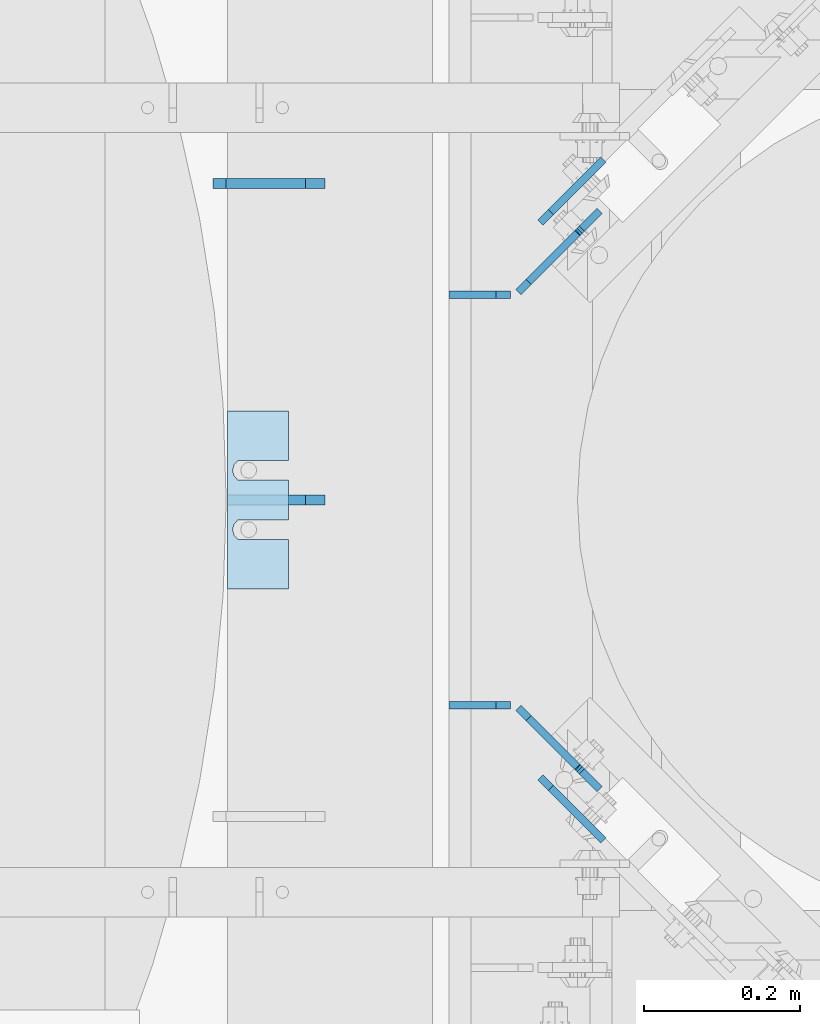
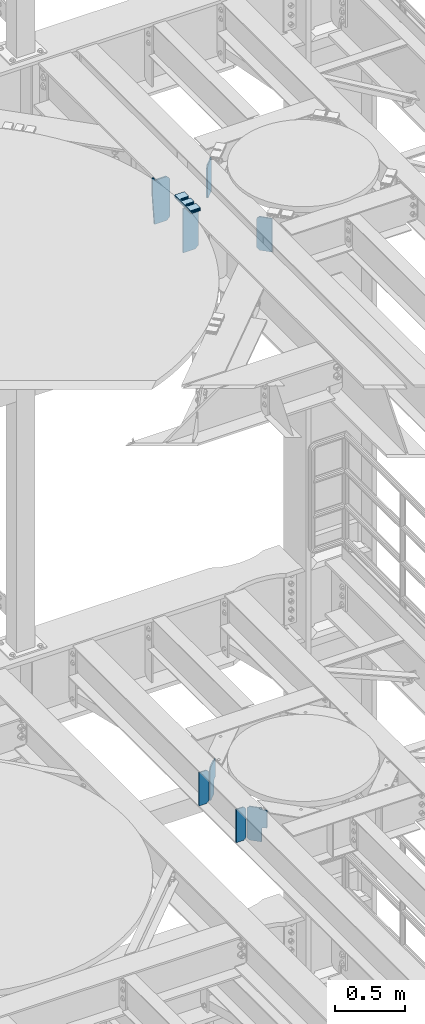
# One storey, part 1789 of 1876: 14 plates, 9 elements without a shape of their own.
"""IFC2X3 building model written with IfcOpenShell, lengths in millimetres."""

from ifc_helpers import new_model, si_unit, frame, origin_with_axes, place, context, subcontext, project, spatial, faceted_brep, material, type_object, element, aggregate, save


model = new_model("IFC2X3")

# Units and contexts
model_context = context("Model", 3, precision=1e-05, world=origin_with_axes())
body_context = subcontext(model_context, "Body", "Model", "MODEL_VIEW")
ifc_project = project(units=[si_unit("LENGTHUNIT", "METRE", prefix="MILLI"), si_unit("AREAUNIT", "SQUARE_METRE"), si_unit("VOLUMEUNIT", "CUBIC_METRE"), si_unit("MASSUNIT", "GRAM", prefix="KILO"), si_unit("TIMEUNIT", "SECOND"), si_unit("PLANEANGLEUNIT", "RADIAN"), si_unit("SOLIDANGLEUNIT", "STERADIAN"), si_unit("THERMODYNAMICTEMPERATUREUNIT", "DEGREE_CELSIUS"), si_unit("LUMINOUSINTENSITYUNIT", "LUMEN")], contexts=[model_context])

# Site, building, storey
site_placement = place(None, origin_with_axes())
site = spatial("IfcSite", under=ifc_project, at=site_placement, CompositionType="ELEMENT")
building_placement = place(site_placement, origin_with_axes())
building = spatial("IfcBuilding", under=site, at=building_placement, Name="Undefined", CompositionType="ELEMENT")
storey_placement = place(building_placement, origin_with_axes())
storey = spatial("IfcBuildingStorey", under=building, at=storey_placement, Name="Undefined", CompositionType="ELEMENT", Elevation=0.0)

# Assembly, plates
assembly_1_placement = place(storey_placement, origin_with_axes())
assembly_1 = element("IfcElementAssembly", 1, at=assembly_1_placement, inside=storey, Name="BEAM", AssemblyPlace="NOTDEFINED", PredefinedType="RIGID_FRAME")
ifc_material = material(Name="STEEL/A36")
plate_type_1 = type_object("IfcPlateType", PredefinedType="NOTDEFINED")
plate_1_placement = place(assembly_1_placement, frame((5483.225, 11217.5243572982, 7851.775), z_axis=(0.0, 0.0, 1.0), x_axis=(-1.0, 0.0, 0.0)))
plate_1 = element("IfcPlate", 2, at=plate_1_placement, type_object=plate_type_1, material=ifc_material, Name="PLATE", context=body_context, shape_type="Brep", body=[
    faceted_brep([(0.0, -4.76249999999982, 19.0499992370605), (0.0, -4.76250000000073, 269.874988555908), (0.0, 4.76250000000073, 269.874988555908), (0.0, 4.76249999999982, 19.0499992370605), (19.0499992370605, -4.76250000000073, 288.924987792969), (19.0499992370605, 4.76250000000073, 288.924987792969), (79.375, -4.76250000000073, 288.924987792969), (79.375, 4.76250000000073, 288.924987792969), (79.375, -4.76250000000073, 0.0), (79.375, 4.76250000000073, 0.0), (19.0499992370605, -4.76249999999982, 0.0), (19.0499992370605, 4.76249999999982, 0.0)], [[[0, 1, 2, 3]], [[1, 4, 5, 2]], [[4, 6, 7, 5]], [[6, 8, 9, 7]], [[8, 10, 11, 9]], [[10, 0, 3, 11]], [[5, 7, 9, 11, 3, 2]], [[10, 8, 6, 4, 1, 0]]]),
])
plate_2_placement = place(assembly_1_placement, frame((5483.225, 11744.0756426965, 7851.775), z_axis=(0.0, 0.0, 1.0), x_axis=(-1.0, 0.0, 0.0)))
plate_2 = element("IfcPlate", 3, at=plate_2_placement, type_object=plate_type_1, material=ifc_material, Name="PLATE", context=body_context, shape_type="Brep", body=[
    faceted_brep([(0.0, -4.76249999999982, 19.0499992370605), (0.0, -4.76250000000073, 269.874988555908), (0.0, 4.76250000000073, 269.874988555908), (0.0, 4.76249999999982, 19.0499992370605), (19.0499992370605, -4.76250000000073, 288.924987792969), (19.0499992370605, 4.76250000000073, 288.924987792969), (79.375, -4.76250000000073, 288.924987792969), (79.375, 4.76250000000073, 288.924987792969), (79.375, -4.76250000000073, 0.0), (79.375, 4.76250000000073, 0.0), (19.0499992370605, -4.76249999999982, 0.0), (19.0499992370605, 4.76249999999982, 0.0)], [[[0, 1, 2, 3]], [[1, 4, 5, 2]], [[4, 6, 7, 5]], [[6, 8, 9, 7]], [[8, 10, 11, 9]], [[10, 0, 3, 11]], [[5, 7, 9, 11, 3, 2]], [[10, 8, 6, 4, 1, 0]]]),
])
plate_type_2 = type_object("IfcPlateType", PredefinedType="NOTDEFINED")
plate_3_placement = place(assembly_1_placement, frame((5492.9414299445, 11214.1593446803, 7869.2375), z_axis=(0.500120633849916, -0.499879336849988, 0.707106781319465), x_axis=(0.500120634037912, -0.499879337037939, -0.707106781053631)))
plate_3 = element("IfcPlate", 4, at=plate_3_placement, type_object=plate_type_2, material=ifc_material, Name="PLATE", context=body_context, shape_type="Brep", body=[
    faceted_brep([(0.0, -4.76249999999982, 0.0), (-179.605117797772, -4.76249999999527, 179.605117797992), (-179.605117797772, 4.76250000000437, 179.605117797993), (0.0, 4.76249999999982, 0.0), (-179.605117797761, -4.76249999999891, 206.545883178862), (-179.605117797761, 4.76250000000255, 206.545883178861), (-117.085624694717, -4.76250000001346, 269.065399170066), (-117.085624694717, 4.76249999998618, 269.065399170067), (-115.963089848394, -4.76250000001346, 267.942865171457), (-115.963089848394, 4.76249999998618, 267.942865171458), (-111.842913448323, -4.76250000001346, 265.189853285486), (-111.842913448321, 4.76249999998618, 265.189853285486), (-106.982834855353, -4.76250000001528, 264.223124739228), (-106.982834855355, 4.76249999998618, 264.223124739228), (-102.122756627408, -4.7625000000171, 265.189855120591), (-102.122756627408, 4.76249999998436, 265.189855120592), (-98.0025812668409, -4.7625000000171, 267.942868562291), (-98.0025812668409, 4.76249999998436, 267.942868562292), (-78.5502777098482, -4.76250000002074, 287.395172119276), (-78.55027770985, 4.76249999997708, 287.395172119276), (29.2127933502834, -4.76250000002437, 179.632080078175), (29.2127933502834, 4.76249999997526, 179.632080078175), (13.1280894640131, -4.76250000002074, 163.547375922156), (13.1280894640131, 4.7624999999789, 163.547375922156), (9.34269542473339, -4.76250000002074, 157.882133286667), (9.34269542473339, 4.76249999998072, 157.882133286666), (8.01344184574918, -4.76250000001892, 151.199523985329), (8.01344184574918, 4.76249999998072, 151.199523985328), (9.34269553466402, -4.76250000001892, 144.516914705855), (9.34269553466402, 4.76249999998254, 144.516914705854), (13.1280896671378, -4.76250000001892, 138.851672132636), (13.1280896671378, 4.76249999998072, 138.851672132635), (89.4602661132976, -4.76250000002256, 62.5194969177073), (89.4602661132976, 4.7624999999789, 62.5194969177082), (26.9407691955548, -4.76250000000618, -2.22826201934367e-11), (26.9407691955548, 4.76249999999345, -2.22826201934367e-11)], [[[0, 1, 2, 3]], [[1, 4, 5, 2]], [[4, 6, 7, 5]], [[6, 8, 9, 7]], [[8, 10, 11, 9]], [[10, 12, 13, 11]], [[12, 14, 15, 13]], [[14, 16, 17, 15]], [[16, 18, 19, 17]], [[18, 20, 21, 19]], [[20, 22, 23, 21]], [[22, 24, 25, 23]], [[24, 26, 27, 25]], [[26, 28, 29, 27]], [[28, 30, 31, 29]], [[30, 32, 33, 31]], [[32, 34, 35, 33]], [[34, 0, 3, 35]], [[5, 7, 9, 11, 13, 15, 17, 19, 21, 23, 25, 27, 29, 31, 33, 35, 3, 2]], [[34, 32, 30, 28, 26, 24, 22, 20, 18, 16, 14, 12, 10, 8, 6, 4, 1, 0]]]),
])
plate_4_placement = place(assembly_1_placement, frame((5492.94142994366, 11747.4406553139, 7869.2375), z_axis=(0.500120633849922, 0.499879336849994, 0.707106781319457), x_axis=(0.500120634037941, 0.499879337037901, -0.707106781053638)))
plate_4 = element("IfcPlate", 5, at=plate_4_placement, type_object=plate_type_2, material=ifc_material, Name="PLATE", context=body_context, shape_type="Brep", body=[
    faceted_brep([(0.0, -4.76249999999982, 0.0), (-179.605117797772, -4.76249999999527, 179.605117797992), (-179.605117797772, 4.76250000000437, 179.605117797993), (0.0, 4.76249999999982, 0.0), (-179.605117797761, -4.76249999999891, 206.545883178862), (-179.605117797761, 4.76250000000255, 206.545883178861), (-117.085624694717, -4.76250000001346, 269.065399170066), (-117.085624694717, 4.76249999998618, 269.065399170067), (-115.963089848394, -4.76250000001346, 267.942865171457), (-115.963089848394, 4.76249999998618, 267.942865171458), (-111.842913448323, -4.76250000001346, 265.189853285486), (-111.842913448321, 4.76249999998618, 265.189853285486), (-106.982834855353, -4.76250000001528, 264.223124739228), (-106.982834855355, 4.76249999998618, 264.223124739228), (-102.122756627408, -4.7625000000171, 265.189855120591), (-102.122756627408, 4.76249999998436, 265.189855120592), (-98.0025812668409, -4.7625000000171, 267.942868562291), (-98.0025812668409, 4.76249999998436, 267.942868562292), (-78.5502777098482, -4.76250000002074, 287.395172119276), (-78.55027770985, 4.76249999997708, 287.395172119276), (29.2127933502834, -4.76250000002437, 179.632080078175), (29.2127933502834, 4.76249999997526, 179.632080078175), (13.1280894640131, -4.76250000002074, 163.547375922156), (13.1280894640131, 4.7624999999789, 163.547375922156), (9.34269542473339, -4.76250000002074, 157.882133286667), (9.34269542473339, 4.76249999998072, 157.882133286666), (8.01344184574918, -4.76250000001892, 151.199523985329), (8.01344184574918, 4.76249999998072, 151.199523985328), (9.34269553466402, -4.76250000001892, 144.516914705855), (9.34269553466402, 4.76249999998254, 144.516914705854), (13.1280896671378, -4.76250000001892, 138.851672132636), (13.1280896671378, 4.76249999998072, 138.851672132635), (89.4602661132976, -4.76250000002256, 62.5194969177073), (89.4602661132976, 4.7624999999789, 62.5194969177082), (26.9407691955548, -4.76250000000618, -2.22826201934367e-11), (26.9407691955548, 4.76249999999345, -2.22826201934367e-11)], [[[0, 1, 2, 3]], [[1, 4, 5, 2]], [[4, 6, 7, 5]], [[6, 8, 9, 7]], [[8, 10, 11, 9]], [[10, 12, 13, 11]], [[12, 14, 15, 13]], [[14, 16, 17, 15]], [[16, 18, 19, 17]], [[18, 20, 21, 19]], [[20, 22, 23, 21]], [[22, 24, 25, 23]], [[24, 26, 27, 25]], [[26, 28, 29, 27]], [[28, 30, 31, 29]], [[30, 32, 33, 31]], [[32, 34, 35, 33]], [[34, 0, 3, 35]], [[5, 7, 9, 11, 13, 15, 17, 19, 21, 23, 25, 27, 29, 31, 33, 35, 3, 2]], [[34, 32, 30, 28, 26, 24, 22, 20, 18, 16, 14, 12, 10, 8, 6, 4, 1, 0]]]),
])
aggregate(assembly_1, [plate_1, plate_3, plate_2, plate_4])

# Assembly, plate
assembly_2_placement = place(storey_placement, origin_with_axes())
assembly_2 = element("IfcElementAssembly", 6, at=assembly_2_placement, inside=storey, Name="SHIM PLATE", AssemblyPlace="NOTDEFINED", PredefinedType="RIGID_FRAME")
plate_type_3 = type_object("IfcPlateType", PredefinedType="NOTDEFINED")
plate_5_placement = place(assembly_2_placement, frame((5197.83164367676, 11366.5000039719, 13335.7925), z_axis=(0.0, 1.0, 0.0), x_axis=(-1.0, 0.0, 0.0)))
plate_5 = element("IfcPlate", 7, at=plate_5_placement, type_object=plate_type_3, material=ifc_material, Name="SHIM PLATE", context=body_context, shape_type="Brep", body=[
    faceted_brep([(-2.69435986410826e-07, -0.793499999999767, 88.9036802523933), (-2.69435986410826e-07, 0.793499999999767, 88.9036802523933), (64.2911367327433, 0.793499999999767, 88.9036792552815), (64.2911367327433, -0.793499999999767, 88.9036792552815), (69.5263870263134, 0.793499999999767, 83.4898931996304), (69.5263870263134, -0.793499999999767, 83.4898931996304), (64.2911372418785, -0.793499999999767, 63.5056518232686), (64.2911372418785, 0.793499999999767, 63.5056518232686), (-1.92456354852766e-07, 0.793499999999767, 63.5036806291719), (-1.92456354852766e-07, -0.793499999999767, 63.5036806291719), (69.5263873183976, -0.793499999999767, 68.9194380887848), (69.5263873183976, 0.793499999999767, 68.9194380887848), (71.4348903969494, -0.793499999999767, 76.2046656824614), (71.4348903969494, 0.793499999999767, 76.2046656824614), (64.2911372419712, -0.793499999999767, 139.705651823344), (64.2911372419712, 0.793499999999767, 139.705651823344), (-4.23393430537544e-07, 0.793499999999767, 139.703680607393), (-4.23393430537544e-07, -0.793499999999767, 139.703680607393), (69.5263873184904, -0.793499999999767, 145.119438088858), (69.5263873184904, 0.793499999999767, 145.119438088858), (71.434890397044, -0.793499999999767, 152.404665682535), (71.434890397044, 0.793499999999767, 152.404665682535), (69.5263870264062, -0.793499999999767, 159.689893199704), (69.5263870264062, 0.793499999999767, 159.689893199704), (64.2911367328379, -0.793499999999767, 165.103679255353), (64.2911367328379, 0.793499999999767, 165.103679255353), (-5.00373062095605e-07, -0.793499999999767, 165.103680230615), (-5.00373062095605e-07, 0.793499999999767, 165.103680230615), (-6.92811227054335e-07, -0.793499999999767, 228.601303100698), (-6.92811227054335e-07, 0.793499999999767, 228.601303100698), (78.1460113524699, -0.793499999999767, 228.601303100651), (78.1460113524699, 0.793499999999767, 228.601303100651), (78.1460113525918, -0.793499999999767, -4.91127138957381e-11), (78.1460113525918, 0.793499999999767, -4.91127138957381e-11), (9.09494701772928e-13, -0.793499999999767, 0.0), (9.09494701772928e-13, 0.793499999999767, 0.0)], [[[0, 1, 2, 3]], [[3, 2, 4, 5]], [[6, 7, 8, 9]], [[10, 11, 7, 6]], [[12, 13, 11, 10]], [[5, 4, 13, 12]], [[14, 15, 16, 17]], [[18, 19, 15, 14]], [[20, 21, 19, 18]], [[22, 23, 21, 20]], [[24, 25, 23, 22]], [[26, 27, 25, 24]], [[28, 29, 27, 26]], [[28, 30, 31, 29]], [[30, 32, 33, 31]], [[32, 34, 35, 33]], [[35, 34, 9, 8]], [[2, 1, 16, 15, 19, 21, 23, 25, 27, 29, 31, 33, 35, 8, 7, 11, 13, 4]], [[17, 16, 1, 0]], [[6, 9, 34, 32, 30, 28, 26, 24, 22, 20, 18, 14, 17, 0, 3, 5, 12, 10]]]),
])
aggregate(assembly_2, [plate_5])

assembly_3_placement = place(storey_placement, origin_with_axes())
assembly_3 = element("IfcElementAssembly", 8, at=assembly_3_placement, inside=storey, Name="SHIM PLATE", AssemblyPlace="NOTDEFINED", PredefinedType="RIGID_FRAME")
plate_type_4 = type_object("IfcPlateType", PredefinedType="NOTDEFINED")
plate_6_placement = place(assembly_3_placement, frame((5197.83164367676, 11366.5000039719, 13333.4115), z_axis=(0.0, 1.0, 0.0), x_axis=(-1.0, 0.0, 0.0)))
plate_6 = element("IfcPlate", 9, at=plate_6_placement, type_object=plate_type_4, material=ifc_material, Name="SHIM PLATE", context=body_context, shape_type="Brep", body=[
    faceted_brep([(-2.69435986410826e-07, -1.58749999999964, 88.9036802523951), (-2.69435986410826e-07, 1.58749999999964, 88.9036802523951), (64.2911367327433, 1.58749999999964, 88.9036792552824), (64.2911367327433, -1.58749999999964, 88.9036792552824), (69.5263870263134, 1.58749999999964, 83.4898931996322), (69.5263870263134, -1.58749999999964, 83.4898931996322), (64.2911372418766, -1.58749999999964, 63.5056518232714), (64.2911372418766, 1.58749999999964, 63.5056518232714), (-1.92456354852766e-07, 1.58749999999964, 63.5036806291737), (-1.92456354852766e-07, -1.58749999999964, 63.5036806291737), (69.5263873183958, -1.58749999999964, 68.9194380887884), (69.5263873183958, 1.58749999999964, 68.9194380887884), (71.4348903969494, -1.58749999999964, 76.2046656824641), (71.4348903969494, 1.58749999999964, 76.2046656824641), (64.2911372419694, -1.58749999999964, 139.705651823345), (64.2911372419694, 1.58749999999964, 139.705651823345), (-4.23391611548141e-07, 1.58749999999964, 139.703680607395), (-4.23391611548141e-07, -1.58749999999964, 139.703680607395), (69.5263873184886, -1.58749999999964, 145.119438088862), (69.5263873184886, 1.58749999999964, 145.119438088862), (71.434890397044, -1.58749999999964, 152.404665682537), (71.434890397044, 1.58749999999964, 152.404665682537), (69.5263870264062, -1.58749999999964, 159.689893199708), (69.5263870264062, 1.58749999999964, 159.689893199708), (64.2911367328361, -1.58749999999964, 165.103679255356), (64.2911367328361, 1.58749999999964, 165.103679255356), (-5.00371243106201e-07, -1.58749999999964, 165.103680230615), (-5.00371243106201e-07, 1.58749999999964, 165.103680230615), (-6.92813046043739e-07, -1.58749999999964, 228.601303100699), (-6.92813046043739e-07, 1.58749999999964, 228.601303100699), (78.1460113524699, -1.58749999999964, 228.601303100651), (78.1460113524699, 1.58749999999964, 228.601303100651), (78.1460113525918, -1.58749999999964, -4.72937244921923e-11), (78.1460113525918, 1.58749999999964, -4.72937244921923e-11), (9.09494701772928e-13, -1.58750000000146, 4.54747350886464e-13), (9.09494701772928e-13, 1.58750000000146, 4.54747350886464e-13)], [[[0, 1, 2, 3]], [[3, 2, 4, 5]], [[6, 7, 8, 9]], [[10, 11, 7, 6]], [[12, 13, 11, 10]], [[5, 4, 13, 12]], [[14, 15, 16, 17]], [[18, 19, 15, 14]], [[20, 21, 19, 18]], [[22, 23, 21, 20]], [[24, 25, 23, 22]], [[26, 27, 25, 24]], [[28, 29, 27, 26]], [[28, 30, 31, 29]], [[30, 32, 33, 31]], [[32, 34, 35, 33]], [[35, 34, 9, 8]], [[2, 1, 16, 15, 19, 21, 23, 25, 27, 29, 31, 33, 35, 8, 7, 11, 13, 4]], [[17, 16, 1, 0]], [[6, 9, 34, 32, 30, 28, 26, 24, 22, 20, 18, 14, 17, 0, 3, 5, 12, 10]]]),
])
aggregate(assembly_3, [plate_6])

assembly_4_placement = place(storey_placement, origin_with_axes())
assembly_4 = element("IfcElementAssembly", 10, at=assembly_4_placement, inside=storey, Name="SHIM PLATE", AssemblyPlace="NOTDEFINED", PredefinedType="RIGID_FRAME")
plate_7_placement = place(assembly_4_placement, frame((5197.83164367676, 11366.5000039719, 13330.2365), z_axis=(0.0, 1.0, 0.0), x_axis=(-1.0, 0.0, 0.0)))
plate_7 = element("IfcPlate", 11, at=plate_7_placement, type_object=plate_type_4, material=ifc_material, Name="SHIM PLATE", context=body_context, shape_type="Brep", body=[
    faceted_brep([(-2.69435986410826e-07, -1.58749999999964, 88.9036802523951), (-2.69435986410826e-07, 1.58749999999964, 88.9036802523951), (64.2911367327433, 1.58749999999964, 88.9036792552824), (64.2911367327433, -1.58749999999964, 88.9036792552824), (69.5263870263134, 1.58749999999964, 83.4898931996322), (69.5263870263134, -1.58749999999964, 83.4898931996322), (64.2911372418766, -1.58749999999964, 63.5056518232714), (64.2911372418766, 1.58749999999964, 63.5056518232714), (-1.92456354852766e-07, 1.58749999999964, 63.5036806291737), (-1.92456354852766e-07, -1.58749999999964, 63.5036806291737), (69.5263873183958, -1.58749999999964, 68.9194380887884), (69.5263873183958, 1.58749999999964, 68.9194380887884), (71.4348903969494, -1.58749999999964, 76.2046656824641), (71.4348903969494, 1.58749999999964, 76.2046656824641), (64.2911372419694, -1.58749999999964, 139.705651823345), (64.2911372419694, 1.58749999999964, 139.705651823345), (-4.23391611548141e-07, 1.58749999999964, 139.703680607395), (-4.23391611548141e-07, -1.58749999999964, 139.703680607395), (69.5263873184886, -1.58749999999964, 145.119438088862), (69.5263873184886, 1.58749999999964, 145.119438088862), (71.434890397044, -1.58749999999964, 152.404665682537), (71.434890397044, 1.58749999999964, 152.404665682537), (69.5263870264062, -1.58749999999964, 159.689893199708), (69.5263870264062, 1.58749999999964, 159.689893199708), (64.2911367328361, -1.58749999999964, 165.103679255356), (64.2911367328361, 1.58749999999964, 165.103679255356), (-5.00371243106201e-07, -1.58749999999964, 165.103680230615), (-5.00371243106201e-07, 1.58749999999964, 165.103680230615), (-6.92813046043739e-07, -1.58749999999964, 228.601303100699), (-6.92813046043739e-07, 1.58749999999964, 228.601303100699), (78.1460113524699, -1.58749999999964, 228.601303100651), (78.1460113524699, 1.58749999999964, 228.601303100651), (78.1460113525918, -1.58749999999964, -4.72937244921923e-11), (78.1460113525918, 1.58749999999964, -4.72937244921923e-11), (9.09494701772928e-13, -1.58750000000146, 4.54747350886464e-13), (9.09494701772928e-13, 1.58750000000146, 4.54747350886464e-13)], [[[0, 1, 2, 3]], [[3, 2, 4, 5]], [[6, 7, 8, 9]], [[10, 11, 7, 6]], [[12, 13, 11, 10]], [[5, 4, 13, 12]], [[14, 15, 16, 17]], [[18, 19, 15, 14]], [[20, 21, 19, 18]], [[22, 23, 21, 20]], [[24, 25, 23, 22]], [[26, 27, 25, 24]], [[28, 29, 27, 26]], [[28, 30, 31, 29]], [[30, 32, 33, 31]], [[32, 34, 35, 33]], [[35, 34, 9, 8]], [[2, 1, 16, 15, 19, 21, 23, 25, 27, 29, 31, 33, 35, 8, 7, 11, 13, 4]], [[17, 16, 1, 0]], [[6, 9, 34, 32, 30, 28, 26, 24, 22, 20, 18, 14, 17, 0, 3, 5, 12, 10]]]),
])
aggregate(assembly_4, [plate_7])

assembly_5_placement = place(storey_placement, origin_with_axes())
assembly_5 = element("IfcElementAssembly", 12, at=assembly_5_placement, inside=storey, Name="SHIM PLATE", AssemblyPlace="NOTDEFINED", PredefinedType="RIGID_FRAME")
plate_type_5 = type_object("IfcPlateType", PredefinedType="NOTDEFINED")
plate_8_placement = place(assembly_5_placement, frame((5197.83164367676, 11366.5000039719, 13326.268), z_axis=(0.0, 1.0, 0.0), x_axis=(-1.0, 0.0, 0.0)))
plate_8 = element("IfcPlate", 13, at=plate_8_placement, type_object=plate_type_5, material=ifc_material, Name="SHIM PLATE", context=body_context, shape_type="Brep", body=[
    faceted_brep([(-2.69435986410826e-07, -2.3809999999994, 88.9036802523951), (-2.69435986410826e-07, 2.3809999999994, 88.9036802523951), (64.2911367327433, 2.3809999999994, 88.9036792552824), (64.2911367327433, -2.3809999999994, 88.9036792552824), (69.5263870263134, 2.3809999999994, 83.4898931996322), (69.5263870263134, -2.3809999999994, 83.4898931996322), (64.2911372418766, -2.3809999999994, 63.5056518232714), (64.2911372418766, 2.3809999999994, 63.5056518232714), (-1.92456354852766e-07, 2.3809999999994, 63.5036806291737), (-1.92456354852766e-07, -2.3809999999994, 63.5036806291737), (69.5263873183958, -2.3809999999994, 68.9194380887884), (69.5263873183958, 2.3809999999994, 68.9194380887884), (71.4348903969494, -2.3809999999994, 76.2046656824641), (71.4348903969494, 2.3809999999994, 76.2046656824641), (64.2911372419694, -2.3809999999994, 139.705651823345), (64.2911372419694, 2.3809999999994, 139.705651823345), (-4.23391611548141e-07, 2.3809999999994, 139.703680607395), (-4.23391611548141e-07, -2.3809999999994, 139.703680607395), (69.5263873184886, -2.3809999999994, 145.119438088862), (69.5263873184886, 2.3809999999994, 145.119438088862), (71.434890397044, -2.3809999999994, 152.404665682537), (71.434890397044, 2.3809999999994, 152.404665682537), (69.5263870264062, -2.3809999999994, 159.689893199708), (69.5263870264062, 2.3809999999994, 159.689893199708), (64.2911367328361, -2.3809999999994, 165.103679255356), (64.2911367328361, 2.3809999999994, 165.103679255356), (-5.00371243106201e-07, -2.3809999999994, 165.103680230615), (-5.00371243106201e-07, 2.3809999999994, 165.103680230615), (-6.92813046043739e-07, -2.3809999999994, 228.601303100699), (-6.92813046043739e-07, 2.3809999999994, 228.601303100699), (78.1460113524699, -2.3809999999994, 228.601303100651), (78.1460113524699, 2.3809999999994, 228.601303100651), (78.1460113525918, -2.3809999999994, -4.72937244921923e-11), (78.1460113525918, 2.3809999999994, -4.72937244921923e-11), (0.0, -2.38100000000122, 4.54747350886464e-13), (0.0, 2.38100000000122, 4.54747350886464e-13)], [[[0, 1, 2, 3]], [[3, 2, 4, 5]], [[6, 7, 8, 9]], [[10, 11, 7, 6]], [[12, 13, 11, 10]], [[5, 4, 13, 12]], [[14, 15, 16, 17]], [[18, 19, 15, 14]], [[20, 21, 19, 18]], [[22, 23, 21, 20]], [[24, 25, 23, 22]], [[26, 27, 25, 24]], [[28, 29, 27, 26]], [[28, 30, 31, 29]], [[30, 32, 33, 31]], [[32, 34, 35, 33]], [[35, 34, 9, 8]], [[2, 1, 16, 15, 19, 21, 23, 25, 27, 29, 31, 33, 35, 8, 7, 11, 13, 4]], [[17, 16, 1, 0]], [[6, 9, 34, 32, 30, 28, 26, 24, 22, 20, 18, 14, 17, 0, 3, 5, 12, 10]]]),
])
aggregate(assembly_5, [plate_8])

assembly_6_placement = place(storey_placement, origin_with_axes())
assembly_6 = element("IfcElementAssembly", 14, at=assembly_6_placement, inside=storey, Name="SHIM PLATE", AssemblyPlace="NOTDEFINED", PredefinedType="RIGID_FRAME")
plate_9_placement = place(assembly_6_placement, frame((5197.83164367676, 11366.5000039719, 13321.506), z_axis=(0.0, 1.0, 0.0), x_axis=(-1.0, 0.0, 0.0)))
plate_9 = element("IfcPlate", 15, at=plate_9_placement, type_object=plate_type_5, material=ifc_material, Name="SHIM PLATE", context=body_context, shape_type="Brep", body=[
    faceted_brep([(-2.69435986410826e-07, -2.3809999999994, 88.9036802523951), (-2.69435986410826e-07, 2.3809999999994, 88.9036802523951), (64.2911367327433, 2.3809999999994, 88.9036792552824), (64.2911367327433, -2.3809999999994, 88.9036792552824), (69.5263870263134, 2.3809999999994, 83.4898931996322), (69.5263870263134, -2.3809999999994, 83.4898931996322), (64.2911372418766, -2.3809999999994, 63.5056518232714), (64.2911372418766, 2.3809999999994, 63.5056518232714), (-1.92456354852766e-07, 2.3809999999994, 63.5036806291737), (-1.92456354852766e-07, -2.3809999999994, 63.5036806291737), (69.5263873183958, -2.3809999999994, 68.9194380887884), (69.5263873183958, 2.3809999999994, 68.9194380887884), (71.4348903969494, -2.3809999999994, 76.2046656824641), (71.4348903969494, 2.3809999999994, 76.2046656824641), (64.2911372419694, -2.3809999999994, 139.705651823345), (64.2911372419694, 2.3809999999994, 139.705651823345), (-4.23391611548141e-07, 2.3809999999994, 139.703680607395), (-4.23391611548141e-07, -2.3809999999994, 139.703680607395), (69.5263873184886, -2.3809999999994, 145.119438088862), (69.5263873184886, 2.3809999999994, 145.119438088862), (71.434890397044, -2.3809999999994, 152.404665682537), (71.434890397044, 2.3809999999994, 152.404665682537), (69.5263870264062, -2.3809999999994, 159.689893199708), (69.5263870264062, 2.3809999999994, 159.689893199708), (64.2911367328361, -2.3809999999994, 165.103679255356), (64.2911367328361, 2.3809999999994, 165.103679255356), (-5.00371243106201e-07, -2.3809999999994, 165.103680230615), (-5.00371243106201e-07, 2.3809999999994, 165.103680230615), (-6.92813046043739e-07, -2.3809999999994, 228.601303100699), (-6.92813046043739e-07, 2.3809999999994, 228.601303100699), (78.1460113524699, -2.3809999999994, 228.601303100651), (78.1460113524699, 2.3809999999994, 228.601303100651), (78.1460113525918, -2.3809999999994, -4.72937244921923e-11), (78.1460113525918, 2.3809999999994, -4.72937244921923e-11), (0.0, -2.38100000000122, 4.54747350886464e-13), (0.0, 2.38100000000122, 4.54747350886464e-13)], [[[0, 1, 2, 3]], [[3, 2, 4, 5]], [[6, 7, 8, 9]], [[10, 11, 7, 6]], [[12, 13, 11, 10]], [[5, 4, 13, 12]], [[14, 15, 16, 17]], [[18, 19, 15, 14]], [[20, 21, 19, 18]], [[22, 23, 21, 20]], [[24, 25, 23, 22]], [[26, 27, 25, 24]], [[28, 29, 27, 26]], [[28, 30, 31, 29]], [[30, 32, 33, 31]], [[32, 34, 35, 33]], [[35, 34, 9, 8]], [[2, 1, 16, 15, 19, 21, 23, 25, 27, 29, 31, 33, 35, 8, 7, 11, 13, 4]], [[17, 16, 1, 0]], [[6, 9, 34, 32, 30, 28, 26, 24, 22, 20, 18, 14, 17, 0, 3, 5, 12, 10]]]),
])
aggregate(assembly_6, [plate_9])

assembly_7_placement = place(storey_placement, origin_with_axes())
assembly_7 = element("IfcElementAssembly", 16, at=assembly_7_placement, inside=storey, Name="SHIM PLATE", AssemblyPlace="NOTDEFINED", PredefinedType="RIGID_FRAME")
plate_type_6 = type_object("IfcPlateType", PredefinedType="NOTDEFINED")
plate_10_placement = place(assembly_7_placement, frame((5197.83164367676, 11366.5000039719, 13314.3625), z_axis=(0.0, 1.0, 0.0), x_axis=(-1.0, 0.0, 0.0)))
plate_10 = element("IfcPlate", 17, at=plate_10_placement, type_object=plate_type_6, material=ifc_material, Name="SHIM PLATE", context=body_context, shape_type="Brep", body=[
    faceted_brep([(-2.69435986410826e-07, -4.76250000000073, 88.9036802523951), (-2.69435986410826e-07, 4.76250000000073, 88.9036802523951), (64.2911367327433, 4.76250000000073, 88.9036792552824), (64.2911367327433, -4.76250000000073, 88.9036792552824), (69.5263870263134, 4.76250000000073, 83.4898931996322), (69.5263870263134, -4.76250000000073, 83.4898931996322), (64.2911372418766, -4.76250000000073, 63.5056518232714), (64.2911372418766, 4.76250000000073, 63.5056518232714), (-1.92456354852766e-07, 4.76250000000073, 63.5036806291737), (-1.92456354852766e-07, -4.76250000000073, 63.5036806291737), (69.5263873183958, -4.76250000000073, 68.9194380887884), (69.5263873183958, 4.76250000000073, 68.9194380887884), (71.4348903969494, -4.76250000000073, 76.2046656824641), (71.4348903969494, 4.76250000000073, 76.2046656824641), (64.2911372419694, -4.76250000000073, 139.705651823345), (64.2911372419694, 4.76250000000073, 139.705651823345), (-4.23391611548141e-07, 4.76250000000073, 139.703680607395), (-4.23391611548141e-07, -4.76250000000073, 139.703680607395), (69.5263873184886, -4.76250000000073, 145.119438088862), (69.5263873184886, 4.76250000000073, 145.119438088862), (71.434890397044, -4.76250000000073, 152.404665682537), (71.434890397044, 4.76250000000073, 152.404665682537), (69.5263870264062, -4.76250000000073, 159.689893199708), (69.5263870264062, 4.76250000000073, 159.689893199708), (64.2911367328361, -4.76250000000073, 165.103679255356), (64.2911367328361, 4.76250000000073, 165.103679255356), (-5.00371243106201e-07, -4.76250000000073, 165.103680230615), (-5.00371243106201e-07, 4.76250000000073, 165.103680230615), (-6.92813046043739e-07, -4.76250000000073, 228.601303100699), (-6.92813046043739e-07, 4.76250000000073, 228.601303100699), (78.1460113524699, -4.76250000000073, 228.601303100651), (78.1460113524699, 4.76250000000073, 228.601303100651), (78.1460113525918, -4.76250000000073, -4.72937244921923e-11), (78.1460113525918, 4.76250000000073, -4.72937244921923e-11), (0.0, -4.76249999999982, 0.0), (0.0, 4.76249999999982, 0.0)], [[[0, 1, 2, 3]], [[3, 2, 4, 5]], [[6, 7, 8, 9]], [[10, 11, 7, 6]], [[12, 13, 11, 10]], [[5, 4, 13, 12]], [[14, 15, 16, 17]], [[18, 19, 15, 14]], [[20, 21, 19, 18]], [[22, 23, 21, 20]], [[24, 25, 23, 22]], [[26, 27, 25, 24]], [[28, 29, 27, 26]], [[28, 30, 31, 29]], [[30, 32, 33, 31]], [[32, 34, 35, 33]], [[35, 34, 9, 8]], [[2, 1, 16, 15, 19, 21, 23, 25, 27, 29, 31, 33, 35, 8, 7, 11, 13, 4]], [[17, 16, 1, 0]], [[6, 9, 34, 32, 30, 28, 26, 24, 22, 20, 18, 14, 17, 0, 3, 5, 12, 10]]]),
])
aggregate(assembly_7, [plate_10])

# Assembly, plates
assembly_8_placement = place(storey_placement, origin_with_axes())
assembly_8 = element("IfcElementAssembly", 18, at=assembly_8_placement, inside=storey, Name="BEAM", AssemblyPlace="NOTDEFINED", PredefinedType="RIGID_FRAME")
plate_type_7 = type_object("IfcPlateType", PredefinedType="NOTDEFINED")
plate_11_placement = place(assembly_8_placement, frame((5521.51724255135, 11125.0040480803, 13007.975), z_axis=(0.0, 0.0, 1.0), x_axis=(0.707106781186547, -0.707106781186548, 0.0)))
plate_11 = element("IfcPlate", 19, at=plate_11_placement, type_object=plate_type_7, material=ifc_material, Name="PLATE", context=body_context, shape_type="Brep", body=[
    faceted_brep([(0.0, -4.76249999999982, 19.0499992370605), (0.0, -4.76249999999982, 271.462512969971), (0.0, 4.76249999999982, 271.462512969971), (0.0, 4.76249999999982, 19.0499992370605), (19.0499992370605, -4.76249999999982, 290.512512207031), (19.0499992370605, 4.76249999999982, 290.512512207031), (114.300003051778, -4.76250000000027, 290.512512207031), (114.300003051778, 4.76250000000118, 290.512512207031), (114.300003051758, -4.76249999999999, 0.0), (114.300003051758, 4.76249999999999, 0.0), (19.0499992370605, -4.76249999999982, 0.0), (19.0499992370605, 4.76249999999982, 0.0)], [[[0, 1, 2, 3]], [[1, 4, 5, 2]], [[4, 6, 7, 5]], [[6, 8, 9, 7]], [[8, 10, 11, 9]], [[10, 0, 3, 11]], [[5, 7, 9, 11, 3, 2]], [[10, 8, 6, 4, 1, 0]]]),
])
plate_12_placement = place(assembly_8_placement, frame((5521.51724255135, 11836.5959519145, 13007.975), z_axis=(0.0, 0.0, 1.0), x_axis=(0.707106781186548, 0.707106781186547, 0.0)))
plate_12 = element("IfcPlate", 20, at=plate_12_placement, type_object=plate_type_7, material=ifc_material, Name="PLATE", context=body_context, shape_type="Brep", body=[
    faceted_brep([(0.0, -4.76249999999982, 19.0499992370605), (0.0, -4.76249999999982, 271.462512969971), (0.0, 4.76249999999982, 271.462512969971), (0.0, 4.76249999999982, 19.0499992370605), (19.0499992370605, -4.76249999999982, 290.512512207031), (19.0499992370605, 4.76249999999982, 290.512512207031), (114.300003051778, -4.76250000000027, 290.512512207031), (114.300003051778, 4.76250000000118, 290.512512207031), (114.300003051758, -4.76249999999999, 0.0), (114.300003051758, 4.76249999999999, 0.0), (19.0499992370605, -4.76249999999982, 0.0), (19.0499992370605, 4.76249999999982, 0.0)], [[[0, 1, 2, 3]], [[1, 4, 5, 2]], [[4, 6, 7, 5]], [[6, 8, 9, 7]], [[8, 10, 11, 9]], [[10, 0, 3, 11]], [[5, 7, 9, 11, 3, 2]], [[10, 8, 6, 4, 1, 0]]]),
])
aggregate(assembly_8, [plate_11, plate_12])

assembly_9_placement = place(storey_placement, origin_with_axes())
assembly_9 = element("IfcElementAssembly", 21, at=assembly_9_placement, inside=storey, Name="BEAM", AssemblyPlace="NOTDEFINED", PredefinedType="RIGID_FRAME")
plate_type_8 = type_object("IfcPlateType", PredefinedType="NOTDEFINED")
plate_13_placement = place(assembly_9_placement, frame((5245.09999844433, 11480.8, 12906.375), z_axis=(0.0, 0.0, 1.0), x_axis=(-1.0, 0.0, 0.0)))
plate_13 = element("IfcPlate", 22, at=plate_13_placement, type_object=plate_type_8, material=ifc_material, Name="PLATE", context=body_context, shape_type="Brep", body=[
    faceted_brep([(0.0, -6.35000000000036, 25.4000000000005), (0.0, -6.35000000000036, 355.60000038147), (0.0, 6.35000000000036, 355.60000038147), (0.0, 6.35000000000036, 25.4000000000005), (25.3999996185303, -6.35000000000036, 381.0), (25.3999996185303, 6.35000000000036, 381.0), (125.412498474121, -6.35000000000036, 381.0), (125.412498474121, 6.35000000000036, 381.0), (125.412498474121, -6.35000000000036, 0.0), (125.412498474121, 6.35000000000036, 0.0), (25.3999996185303, -6.34999999999991, 0.0), (25.3999996185303, 6.34999999999991, 0.0)], [[[0, 1, 2, 3]], [[1, 4, 5, 2]], [[4, 6, 7, 5]], [[6, 8, 9, 7]], [[8, 10, 11, 9]], [[10, 0, 3, 11]], [[5, 7, 9, 11, 3, 2]], [[10, 8, 6, 4, 1, 0]]]),
])
plate_type_9 = type_object("IfcPlateType", PredefinedType="NOTDEFINED")
plate_14_placement = place(assembly_9_placement, frame((5119.68749997021, 11887.2, 12906.375), z_axis=(0.0, 0.0, 1.0), x_axis=(1.0, 0.0, 0.0)))
plate_14 = element("IfcPlate", 23, at=plate_14_placement, type_object=plate_type_9, material=ifc_material, Name="PLATE", context=body_context, shape_type="Brep", body=[
    faceted_brep([(0.0, -6.35000000000036, 0.0), (-18.2513217926025, -6.35000000000036, 276.225006103516), (-18.2513217926025, 6.35000000000036, 276.225006103516), (0.0, 6.35000000000036, 0.0), (-18.2517261505127, -6.35000000000036, 403.225006103516), (-18.2517261505127, 6.35000000000036, 403.225006103516), (-1.58749985694885, -6.35000000000036, 403.225006103516), (-1.58749985694885, 6.35000000000036, 403.225006103516), (-1.58775019645691, -6.35000000000036, 380.999969482422), (-1.58775019645691, 6.35000000000036, 380.999969482422), (100.012498855591, -6.35000000000036, 381.0), (100.012498855591, 6.35000000000036, 381.0), (125.412498474121, -6.35000000000036, 355.60000038147), (125.412498474121, 6.35000000000036, 355.60000038147), (125.412498474121, -6.35000000000036, 25.3999996185303), (125.412498474121, 6.35000000000036, 25.3999996185303), (100.012498855591, -6.35000000000036, 0.0), (100.012498855591, 6.35000000000036, 0.0)], [[[0, 1, 2, 3]], [[1, 4, 5, 2]], [[4, 6, 7, 5]], [[6, 8, 9, 7]], [[8, 10, 11, 9]], [[10, 12, 13, 11]], [[12, 14, 15, 13]], [[14, 16, 17, 15]], [[16, 0, 3, 17]], [[5, 7, 9, 11, 13, 15, 17, 3, 2]], [[16, 14, 12, 10, 8, 6, 4, 1, 0]]]),
])
aggregate(assembly_9, [plate_13, plate_14])

save(model, "model.ifc")
